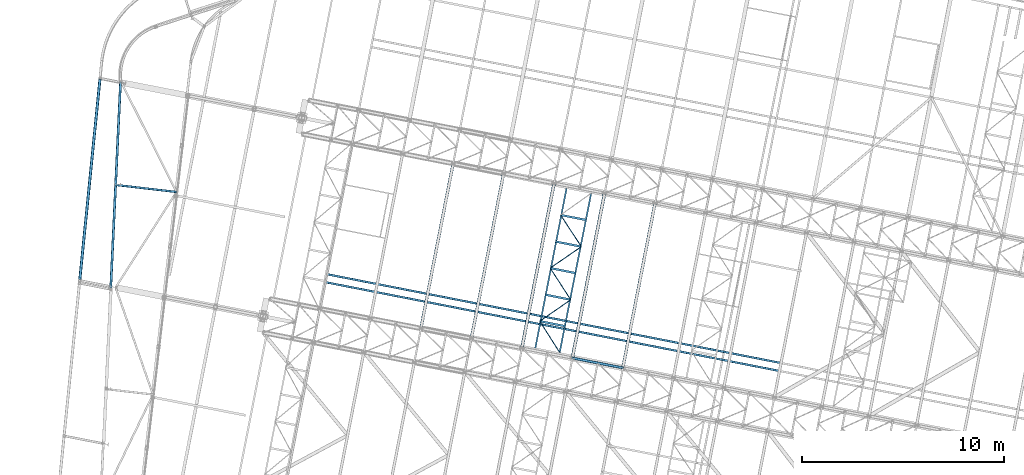
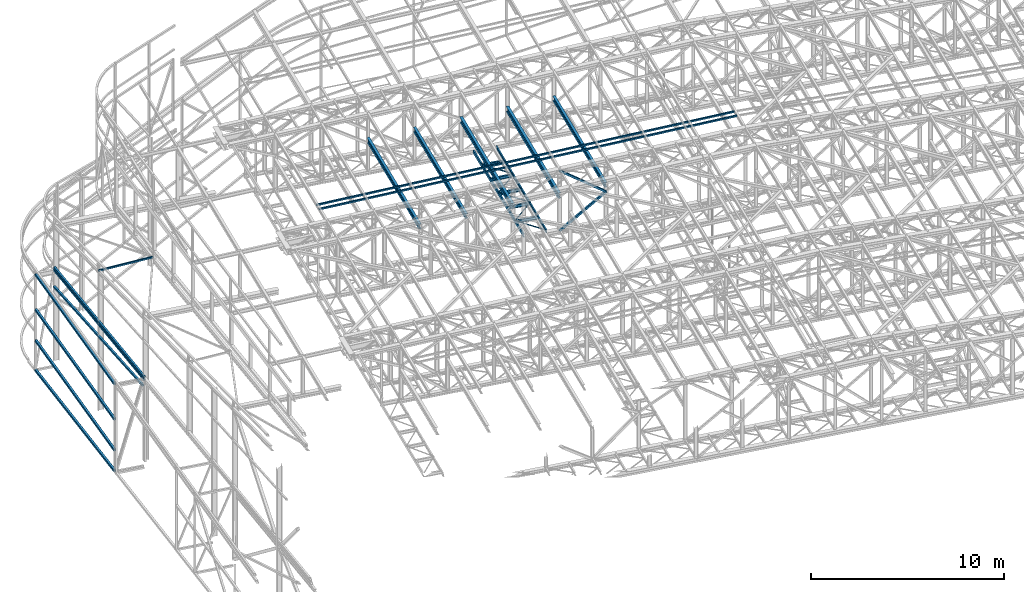
# One storey, part 75 of 215: 27 beams, 2 members, 29 elements without a shape of their own.
"""IFC2X3 building model written with IfcOpenShell, lengths in millimetres."""

from ifc_helpers import new_model, si_unit, frame, origin_with_axes, origin_2d_with_axis, place, context, subcontext, project, spatial, hollow_rectangle, i_section, u_section, extrude, material, type_object, element, aggregate, save


model = new_model("IFC2X3")

# Units and contexts
model_context = context("Model", 3, precision=1e-05, world=origin_with_axes())
body_context = subcontext(model_context, "Body", "Model", "MODEL_VIEW")
ifc_project = project(units=[si_unit("LENGTHUNIT", "METRE", prefix="MILLI"), si_unit("AREAUNIT", "SQUARE_METRE"), si_unit("VOLUMEUNIT", "CUBIC_METRE"), si_unit("MASSUNIT", "GRAM", prefix="KILO"), si_unit("TIMEUNIT", "SECOND"), si_unit("PLANEANGLEUNIT", "RADIAN"), si_unit("SOLIDANGLEUNIT", "STERADIAN"), si_unit("THERMODYNAMICTEMPERATUREUNIT", "DEGREE_CELSIUS"), si_unit("LUMINOUSINTENSITYUNIT", "LUMEN")], contexts=[model_context])

# Site, building, storey
site_placement = place(None, origin_with_axes())
site = spatial("IfcSite", under=ifc_project, at=site_placement, CompositionType="ELEMENT")
building_placement = place(site_placement, origin_with_axes())
building = spatial("IfcBuilding", under=site, at=building_placement, Name="Undefined", CompositionType="ELEMENT")
storey_placement = place(building_placement, origin_with_axes())
storey = spatial("IfcBuildingStorey", under=building, at=storey_placement, Name="Undefined", CompositionType="ELEMENT", Elevation=0.0)

# Assembly, beam
assembly_1_placement = place(storey_placement, origin_with_axes())
assembly_1 = element("IfcElementAssembly", 1, at=assembly_1_placement, inside=storey, Name="Steel Assembly", AssemblyPlace="NOTDEFINED", PredefinedType="RIGID_FRAME")
ifc_material = material(Name="STEEL/S275JR")
beam_type_1 = type_object("IfcBeamType", PredefinedType="NOTDEFINED")
beam_1_placement = place(assembly_1_placement, frame((38562.2210330828, 44215.2225875876, 5303.42054742219), z_axis=(-0.00274567599890538, -0.0584633859767245, 0.998285777602509), x_axis=(0.0475021389989792, 0.997154973978577, 0.0585278109987426)))
beam_1 = element("IfcBeam", 2, at=beam_1_placement, type_object=beam_type_1, material=ifc_material, Name="LISSE", context=body_context, shape_type="SweptSolid", body=[
    extrude(hollow_rectangle(XDim=120.0, YDim=120.0, WallThickness=5.0, InnerFilletRadius=5.0, OuterFilletRadius=10.0, at=origin_2d_with_axis()), frame((10173.8616677264, -8.40086349313258e-14, 1.41190693410765e-13), z_axis=(-1.0, 0.0, 0.0), x_axis=(-6.93889390390723e-18, -1.0, -3.46944695195361e-18)), (0.0, 0.0, 1.0), 10173.9),
])
aggregate(assembly_1, [beam_1])

assembly_2_placement = place(storey_placement, origin_with_axes())
assembly_2 = element("IfcElementAssembly", 3, at=assembly_2_placement, inside=storey, Name="Steel Assembly", AssemblyPlace="NOTDEFINED", PredefinedType="RIGID_FRAME")
beam_2_placement = place(assembly_2_placement, frame((38561.6743863728, 44200.27009948, 5139.85118866705), z_axis=(-0.00585164299790375, -0.0581866479791405, 0.998288571642076), x_axis=(0.0475199150160084, 0.997161649335921, 0.0583995100196734)))
beam_2 = element("IfcBeam", 4, at=beam_2_placement, type_object=beam_type_1, material=ifc_material, Name="LISSE", context=body_context, shape_type="SweptSolid", body=[
    extrude(hollow_rectangle(XDim=120.0, YDim=120.0, WallThickness=5.0, InnerFilletRadius=5.0, OuterFilletRadius=10.0, at=origin_2d_with_axis()), frame((10230.7652524417, -7.68136090467387e-14, 4.54747350886464e-13), z_axis=(-1.0, 0.0, 0.0), x_axis=(-6.93889390390723e-18, -1.0, -3.46944695195361e-18)), (0.0, 0.0, 1.0), 10230.8),
])
aggregate(assembly_2, [beam_2])

assembly_3_placement = place(storey_placement, origin_with_axes())
assembly_3 = element("IfcElementAssembly", 5, at=assembly_3_placement, inside=storey, Name="Steel Assembly", AssemblyPlace="NOTDEFINED", PredefinedType="RIGID_FRAME")
beam_3_placement = place(assembly_3_placement, frame((38569.3547327529, 44361.6215362705, 4673.77424776773), z_axis=(3.64340000136608e-05, -1.73599999892668e-06, 0.999999999334775), x_axis=(0.0475837119818895, 0.998867253619831, 0.0)))
beam_3 = element("IfcBeam", 6, at=beam_3_placement, type_object=beam_type_1, material=ifc_material, Name="LISSE", context=body_context, shape_type="SweptSolid", body=[
    extrude(hollow_rectangle(XDim=120.0, YDim=120.0, WallThickness=5.0, InnerFilletRadius=5.0, OuterFilletRadius=10.0, at=origin_2d_with_axis()), frame((10041.3643397933, 0.0, 0.0), z_axis=(-1.0, 0.0, 0.0), x_axis=(-6.93889390390723e-18, -1.0, -3.46944695195361e-18)), (0.0, 0.0, 1.0), 10041.4),
])
aggregate(assembly_3, [beam_3])

assembly_4_placement = place(storey_placement, origin_with_axes())
assembly_4 = element("IfcElementAssembly", 7, at=assembly_4_placement, inside=storey, Name="Steel Assembly", AssemblyPlace="NOTDEFINED", PredefinedType="RIGID_FRAME")
beam_type_2 = type_object("IfcBeamType", PredefinedType="NOTDEFINED")
beam_4_placement = place(assembly_4_placement, frame((49238.1174662719, 44889.5888265685, 12020.0732133217), z_axis=(0.0304072880144601, -0.0059443590028274, -0.99951991547525), x_axis=(0.980943093982696, -0.191809039996616, 0.0309828749994535)))
beam_4 = element("IfcBeam", 8, at=beam_4_placement, type_object=beam_type_2, material=ifc_material, context=body_context, shape_type="SweptSolid", body=[
    extrude(hollow_rectangle(XDim=100.0, YDim=100.0, WallThickness=5.0, InnerFilletRadius=5.0, OuterFilletRadius=10.0, at=origin_2d_with_axis()), frame((22902.816814498, -7.45768641912541e-12, 0.0), z_axis=(-1.0, 0.0, 0.0), x_axis=(-6.93889390390723e-18, -1.0, -3.46944695195361e-18)), (0.0, 0.0, 1.0), 22902.8),
])
aggregate(assembly_4, [beam_4])

assembly_5_placement = place(storey_placement, origin_with_axes())
assembly_5 = element("IfcElementAssembly", 9, at=assembly_5_placement, inside=storey, Name="Steel Assembly", AssemblyPlace="NOTDEFINED", PredefinedType="RIGID_FRAME")
beam_5_placement = place(assembly_5_placement, frame((49161.3570002445, 44497.0231239916, 12020.0732132829), z_axis=(0.0304072880144601, -0.0059443590028274, -0.99951991547525), x_axis=(0.980943093982696, -0.191809039996616, 0.0309828749994535)))
beam_5 = element("IfcBeam", 10, at=beam_5_placement, type_object=beam_type_2, material=ifc_material, context=body_context, shape_type="SweptSolid", body=[
    extrude(hollow_rectangle(XDim=100.0, YDim=100.0, WallThickness=5.0, InnerFilletRadius=5.0, OuterFilletRadius=10.0, at=origin_2d_with_axis()), frame((22902.816814498, -7.45768641912541e-12, 0.0), z_axis=(-1.0, 0.0, 0.0), x_axis=(-6.93889390390723e-18, -1.0, -3.46944695195361e-18)), (0.0, 0.0, 1.0), 22902.8),
])
aggregate(assembly_5, [beam_5])

assembly_6_placement = place(storey_placement, origin_with_axes())
assembly_6 = element("IfcElementAssembly", 11, at=assembly_6_placement, inside=storey, Name="Steel Assembly", AssemblyPlace="NOTDEFINED", PredefinedType="RIGID_FRAME")
beam_6_placement = place(assembly_6_placement, frame((38743.2654314975, 49309.4022806662, 8864.68109814896), z_axis=(0.115203788960212, 0.992088860657365, -0.0498776459827747), x_axis=(0.993325216792512, -0.115347360975905, -6.30000004858045e-08)))
beam_6 = element("IfcBeam", 12, at=beam_6_placement, type_object=beam_type_2, material=ifc_material, context=body_context, shape_type="SweptSolid", body=[
    extrude(hollow_rectangle(XDim=100.0, YDim=100.0, WallThickness=5.0, InnerFilletRadius=5.0, OuterFilletRadius=10.0, at=origin_2d_with_axis()), frame((3089.93072825559, -1.12759487588544e-15, -7.25438857557065e-12), z_axis=(-1.0, 0.0, 0.0), x_axis=(-6.93889390390723e-18, -1.0, -3.46944695195361e-18)), (0.0, 0.0, 1.0), 3089.9),
])
aggregate(assembly_6, [beam_6])

assembly_7_placement = place(storey_placement, origin_with_axes())
assembly_7 = element("IfcElementAssembly", 13, at=assembly_7_placement, inside=storey, Name="Steel Assembly", AssemblyPlace="NOTDEFINED", PredefinedType="RIGID_FRAME")
beam_type_3 = type_object("IfcBeamType", PredefinedType="NOTDEFINED")
beam_7_placement = place(assembly_7_placement, frame((59777.1653009629, 42564.8547260588, 8745.0), z_axis=(0.0, 0.0, -1.0), x_axis=(0.535507791031596, -0.844530287049826, 0.0)))
beam_7 = element("IfcBeam", 14, at=beam_7_placement, type_object=beam_type_3, material=ifc_material, context=body_context, shape_type="SweptSolid", body=[
    extrude(hollow_rectangle(XDim=50.0, YDim=50.0, WallThickness=3.0, InnerFilletRadius=3.0, OuterFilletRadius=6.0, at=origin_2d_with_axis()), frame((1826.33118355773, -2.02763493057671e-13, 0.0), z_axis=(-1.0, 0.0, 0.0), x_axis=(-6.93889390390723e-18, -1.0, -3.46944695195361e-18)), (0.0, 0.0, 1.0), 1826.3),
])
aggregate(assembly_7, [beam_7])

assembly_8_placement = place(storey_placement, origin_with_axes())
assembly_8 = element("IfcElementAssembly", 15, at=assembly_8_placement, inside=storey, Name="Steel Assembly", AssemblyPlace="NOTDEFINED", PredefinedType="RIGID_FRAME")
beam_8_placement = place(assembly_8_placement, frame((61307.1499519164, 43624.0938464497, 8745.0), z_axis=(0.0, 0.0, -1.0), x_axis=(-0.822187418806876, -0.569216872866298, 0.0)))
beam_8 = element("IfcBeam", 16, at=beam_8_placement, type_object=beam_type_3, material=ifc_material, context=body_context, shape_type="SweptSolid", body=[
    extrude(hollow_rectangle(XDim=50.0, YDim=50.0, WallThickness=3.0, InnerFilletRadius=3.0, OuterFilletRadius=6.0, at=origin_2d_with_axis()), frame((1860.87091076021, 0.0, 0.0), z_axis=(-1.0, 0.0, 0.0), x_axis=(-6.93889390390723e-18, -1.0, -3.46944695195361e-18)), (0.0, 0.0, 1.0), 1860.9),
])
aggregate(assembly_8, [beam_8])

assembly_9_placement = place(storey_placement, origin_with_axes())
assembly_9 = element("IfcElementAssembly", 17, at=assembly_9_placement, inside=storey, Name="Steel Assembly", AssemblyPlace="NOTDEFINED", PredefinedType="RIGID_FRAME")
beam_9_placement = place(assembly_9_placement, frame((60290.4798209445, 45190.6018396635, 8745.0), z_axis=(0.0, 0.0, -1.0), x_axis=(0.544400959129475, -0.8388251281995, 0.0)))
beam_9 = element("IfcBeam", 18, at=beam_9_placement, type_object=beam_type_3, material=ifc_material, context=body_context, shape_type="SweptSolid", body=[
    extrude(hollow_rectangle(XDim=50.0, YDim=50.0, WallThickness=3.0, InnerFilletRadius=3.0, OuterFilletRadius=6.0, at=origin_2d_with_axis()), frame((1867.50246268117, 1.46555824399975e-11, -1.81898940354586e-12), z_axis=(-1.0, 0.0, 0.0), x_axis=(-6.93889390390723e-18, -1.0, -3.46944695195361e-18)), (0.0, 0.0, 1.0), 1867.5),
])
aggregate(assembly_9, [beam_9])

assembly_10_placement = place(storey_placement, origin_with_axes())
assembly_10 = element("IfcElementAssembly", 19, at=assembly_10_placement, inside=storey, Name="Steel Assembly", AssemblyPlace="NOTDEFINED", PredefinedType="RIGID_FRAME")
beam_10_placement = place(assembly_10_placement, frame((61831.9040315537, 46250.4417372231, 8745.0), z_axis=(0.0, 0.0, -1.0), x_axis=(-0.824014283078037, -0.566569026053656, 0.0)))
beam_10 = element("IfcBeam", 20, at=beam_10_placement, type_object=beam_type_3, material=ifc_material, context=body_context, shape_type="SweptSolid", body=[
    extrude(hollow_rectangle(XDim=50.0, YDim=50.0, WallThickness=3.0, InnerFilletRadius=3.0, OuterFilletRadius=6.0, at=origin_2d_with_axis()), frame((1870.62802431259, 1.03840715155045e-13, -1.81898940354586e-12), z_axis=(-1.0, 0.0, 0.0), x_axis=(-6.93889390390723e-18, -1.0, -3.46944695195361e-18)), (0.0, 0.0, 1.0), 1870.6),
])
aggregate(assembly_10, [beam_10])

assembly_11_placement = place(storey_placement, origin_with_axes())
assembly_11 = element("IfcElementAssembly", 21, at=assembly_11_placement, inside=storey, Name="Steel Assembly", AssemblyPlace="NOTDEFINED", PredefinedType="RIGID_FRAME")
beam_11_placement = place(assembly_11_placement, frame((60803.7943409261, 47816.3489532683, 8745.0), z_axis=(0.0, 0.0, -1.0), x_axis=(0.548836682790729, -0.835929599681258, 0.0)))
beam_11 = element("IfcBeam", 22, at=beam_11_placement, type_object=beam_type_3, material=ifc_material, context=body_context, shape_type="SweptSolid", body=[
    extrude(hollow_rectangle(XDim=50.0, YDim=50.0, WallThickness=3.0, InnerFilletRadius=3.0, OuterFilletRadius=6.0, at=origin_2d_with_axis()), frame((1873.25250441599, 1.03986403066968e-13, 0.0), z_axis=(-1.0, 0.0, 0.0), x_axis=(-6.93889390390723e-18, -1.0, -3.46944695195361e-18)), (0.0, 0.0, 1.0), 1873.3),
])
aggregate(assembly_11, [beam_11])

assembly_12_placement = place(storey_placement, origin_with_axes())
assembly_12 = element("IfcElementAssembly", 23, at=assembly_12_placement, inside=storey, Name="Steel Assembly", AssemblyPlace="NOTDEFINED", PredefinedType="RIGID_FRAME")
beam_type_4 = type_object("IfcBeamType", Name="UPN200", PredefinedType="NOTDEFINED")
beam_12_placement = place(assembly_12_placement, frame((61097.2549306837, 49122.0277259823, 8670.00000003361), z_axis=(0.0, 0.0, -1.0), x_axis=(-0.191860814904866, -0.981422145513357, 0.0)))
beam_12 = element("IfcBeam", 24, at=beam_12_placement, type_object=beam_type_4, material=ifc_material, ObjectType="UPN200", context=body_context, shape_type="SweptSolid", body=[
    extrude(u_section(Depth=200.0, FlangeWidth=75.0, WebThickness=8.5, FlangeThickness=11.5, FilletRadius=11.5, EdgeRadius=6.0, FlangeSlope=0.0798299857122373, at=origin_2d_with_axis()), frame((8026.35392374698, 0.0, 0.0), z_axis=(-1.0, 0.0, 0.0), x_axis=(-6.93889390390723e-18, -1.0, -3.46944695195361e-18)), (0.0, 0.0, 1.0), 8026.4),
])
aggregate(assembly_12, [beam_12])

assembly_13_placement = place(storey_placement, origin_with_axes())
assembly_13 = element("IfcElementAssembly", 25, at=assembly_13_placement, inside=storey, Name="Steel Assembly", AssemblyPlace="NOTDEFINED", PredefinedType="RIGID_FRAME")
beam_13_placement = place(assembly_13_placement, frame((60757.1358696871, 41010.3165520345, 8669.99999999997), z_axis=(0.0, 0.0, -1.0), x_axis=(0.194048585919093, 0.980991919590982, 0.0)))
beam_13 = element("IfcBeam", 26, at=beam_13_placement, type_object=beam_type_4, material=ifc_material, ObjectType="UPN200", context=body_context, shape_type="SweptSolid", body=[
    extrude(u_section(Depth=200.0, FlangeWidth=75.0, WebThickness=8.5, FlangeThickness=11.5, FilletRadius=11.5, EdgeRadius=6.0, FlangeSlope=0.0798299857122373, at=origin_2d_with_axis()), frame((8026.37389987571, 0.0, -1.81898940354586e-12), z_axis=(-1.0, 0.0, 0.0), x_axis=(-6.93889390390723e-18, -1.0, -3.46944695195361e-18)), (0.0, 0.0, 1.0), 8026.4),
])
aggregate(assembly_13, [beam_13])

# Assembly, member
assembly_14_placement = place(storey_placement, origin_with_axes())
assembly_14 = element("IfcElementAssembly", 27, at=assembly_14_placement, inside=storey, Name="Steel Assembly", AssemblyPlace="NOTDEFINED", PredefinedType="RIGID_FRAME")
member_type = type_object("IfcMemberType", PredefinedType="NOTDEFINED")
member_1_placement = place(assembly_14_placement, frame((61386.5241832558, 40743.8532211548, 8655.0000016707), z_axis=(0.586513002916786, -0.114658631983731, -0.801782947886243), x_axis=(0.786887629166969, -0.153830279032641, 0.597615348126808)))
member_1 = element("IfcMember", 28, at=member_1_placement, type_object=member_type, material=ifc_material, context=body_context, shape_type="SweptSolid", body=[
    extrude(hollow_rectangle(XDim=120.0, YDim=120.0, WallThickness=5.0, InnerFilletRadius=5.0, OuterFilletRadius=10.0, at=origin_2d_with_axis()), frame((3174.70608727809, -7.28332097910766e-12, -3.8142103968174e-12), z_axis=(-1.0, 0.0, 0.0), x_axis=(-6.93889390390723e-18, -1.0, -3.46944695195361e-18)), (0.0, 0.0, 1.0), 3174.7),
])
aggregate(assembly_14, [member_1])

assembly_15_placement = place(storey_placement, origin_with_axes())
assembly_15 = element("IfcElementAssembly", 29, at=assembly_15_placement, inside=storey, Name="Steel Assembly", AssemblyPlace="NOTDEFINED", PredefinedType="RIGID_FRAME")
member_2_placement = place(assembly_15_placement, frame((61391.8106230572, 40743.5079109192, 12449.5061705353), z_axis=(-0.58722512481538, 0.114797160963911, -0.801241701748098), x_axis=(0.786356610610694, -0.153725552923893, -0.598340818703776)))
member_2 = element("IfcMember", 30, at=member_2_placement, type_object=member_type, material=ifc_material, context=body_context, shape_type="SweptSolid", body=[
    extrude(hollow_rectangle(XDim=120.0, YDim=120.0, WallThickness=5.0, InnerFilletRadius=5.0, OuterFilletRadius=10.0, at=origin_2d_with_axis()), frame((3170.85685098028, 7.36812737105204e-12, -1.76017914187436e-13), z_axis=(-1.0, 0.0, 0.0), x_axis=(-6.93889390390723e-18, -1.0, -3.46944695195361e-18)), (0.0, 0.0, 1.0), 3170.9),
])
aggregate(assembly_15, [member_2])

# Assembly, beam
assembly_16_placement = place(storey_placement, origin_with_axes())
assembly_16 = element("IfcElementAssembly", 31, at=assembly_16_placement, inside=storey, Name="Steel Assembly", AssemblyPlace="NOTDEFINED", PredefinedType="RIGID_FRAME")
beam_type_5 = type_object("IfcBeamType", PredefinedType="NOTDEFINED")
beam_14_placement = place(assembly_16_placement, frame((37033.3962091547, 44629.9517831955, 5135.56406380141), z_axis=(-0.00585008399815806, -0.0581728539817017, 0.998289384686043), x_axis=(0.0998879760056098, 0.993279461055785, 0.0584662680032836)))
beam_14 = element("IfcBeam", 32, at=beam_14_placement, type_object=beam_type_5, material=ifc_material, Name="LISSE", context=body_context, shape_type="SweptSolid", body=[
    extrude(hollow_rectangle(XDim=140.0, YDim=140.0, WallThickness=8.0, InnerFilletRadius=12.0, OuterFilletRadius=20.0, at=origin_2d_with_axis()), frame((9950.69528939539, 7.64058950994035e-14, 5.23794169769688e-13), z_axis=(-1.0, 0.0, 0.0), x_axis=(-6.93889390390723e-18, -1.0, -3.46944695195361e-18)), (0.0, 0.0, 1.0), 9950.7),
])
aggregate(assembly_16, [beam_14])

assembly_17_placement = place(storey_placement, origin_with_axes())
assembly_17 = element("IfcElementAssembly", 33, at=assembly_17_placement, inside=storey, Name="Steel Assembly", AssemblyPlace="NOTDEFINED", PredefinedType="RIGID_FRAME")
beam_15_placement = place(assembly_17_placement, frame((37032.9811404041, 44625.8246965398, -357.437925612628), z_axis=(-7.90469999696792e-05, -0.000781344999710626, 0.999999691625734), x_axis=(0.10006328903585, 0.994980764356481, 0.00078533300028137)))
beam_15 = element("IfcBeam", 34, at=beam_15_placement, type_object=beam_type_5, material=ifc_material, Name="LISSE", context=body_context, shape_type="SweptSolid", body=[
    extrude(hollow_rectangle(XDim=140.0, YDim=140.0, WallThickness=8.0, InnerFilletRadius=12.0, OuterFilletRadius=20.0, at=origin_2d_with_axis()), frame((9973.88934915999, 3.60882633652561e-12, -5.57620476107591e-14), z_axis=(-1.0, 0.0, 0.0), x_axis=(-6.93889390390723e-18, -1.0, -3.46944695195361e-18)), (0.0, 0.0, 1.0), 9973.9),
])
aggregate(assembly_17, [beam_15])

assembly_18_placement = place(storey_placement, origin_with_axes())
assembly_18 = element("IfcElementAssembly", 35, at=assembly_18_placement, inside=storey, Name="Steel Assembly", AssemblyPlace="NOTDEFINED", PredefinedType="RIGID_FRAME")
beam_16_placement = place(assembly_18_placement, frame((37032.9866978869, 44625.8796354954, 952.372401698805), z_axis=(-0.00586626299826645, -0.0582163579827592, 0.998286753704394), x_axis=(0.0998877130350987, 0.993276843349022, 0.05851117202056)))
beam_16 = element("IfcBeam", 36, at=beam_16_placement, type_object=beam_type_5, material=ifc_material, Name="LISSE", context=body_context, shape_type="SweptSolid", body=[
    extrude(hollow_rectangle(XDim=140.0, YDim=140.0, WallThickness=8.0, InnerFilletRadius=12.0, OuterFilletRadius=20.0, at=origin_2d_with_axis()), frame((9950.72151440229, 3.35989963901814e-12, 2.27373675443232e-13), z_axis=(-1.0, 0.0, 0.0), x_axis=(-6.93889390390723e-18, -1.0, -3.46944695195361e-18)), (0.0, 0.0, 1.0), 9950.7),
])
aggregate(assembly_18, [beam_16])

assembly_19_placement = place(storey_placement, origin_with_axes())
assembly_19 = element("IfcElementAssembly", 37, at=assembly_19_placement, inside=storey, Name="Steel Assembly", AssemblyPlace="NOTDEFINED", PredefinedType="RIGID_FRAME")
beam_17_placement = place(assembly_19_placement, frame((37032.9866978927, 44625.8796355577, 2903.95300605924), z_axis=(-0.00586209300040859, -0.0581748990040192, 0.998289195069007), x_axis=(0.0998879580439841, 0.993279272437377, 0.0584695030257462)))
beam_17 = element("IfcBeam", 38, at=beam_17_placement, type_object=beam_type_5, material=ifc_material, Name="LISSE", context=body_context, shape_type="SweptSolid", body=[
    extrude(hollow_rectangle(XDim=140.0, YDim=140.0, WallThickness=8.0, InnerFilletRadius=12.0, OuterFilletRadius=20.0, at=origin_2d_with_axis()), frame((9950.69717850362, -2.27515506409886e-13, 9.64330679049272e-13), z_axis=(-1.0, 0.0, 0.0), x_axis=(-6.93889390390723e-18, -1.0, -3.46944695195361e-18)), (0.0, 0.0, 1.0), 9950.7),
])
aggregate(assembly_19, [beam_17])

assembly_20_placement = place(storey_placement, origin_with_axes())
assembly_20 = element("IfcElementAssembly", 39, at=assembly_20_placement, inside=storey, Name="Steel Assembly", AssemblyPlace="NOTDEFINED", PredefinedType="RIGID_FRAME")
beam_type_6 = type_object("IfcBeamType", Name="IPE300", PredefinedType="NOTDEFINED")
beam_18_placement = place(assembly_20_placement, frame((63883.3237648507, 40256.4390195537, 10961.3100002071), z_axis=(0.0, 0.0, 1.0), x_axis=(0.191879342079262, 0.981418523405397, 1.00000006478113e-09)))
beam_18 = element("IfcBeam", 40, at=beam_18_placement, type_object=beam_type_6, material=ifc_material, Name="SUPPORT", ObjectType="IPE300", context=body_context, shape_type="SweptSolid", body=[
    extrude(i_section(OverallWidth=150.0, OverallDepth=300.0, WebThickness=7.099999905, FlangeThickness=10.69999981, FilletRadius=15.0, at=origin_2d_with_axis()), frame((8306.35394615426, -2.30547635042662e-13, -1.81898940354586e-12), z_axis=(-1.0, 0.0, 0.0), x_axis=(-6.93889390390723e-18, -1.0, -3.46944695195361e-18)), (0.0, 0.0, 1.0), 8306.4),
])
aggregate(assembly_20, [beam_18])

assembly_21_placement = place(storey_placement, origin_with_axes())
assembly_21 = element("IfcElementAssembly", 41, at=assembly_21_placement, inside=storey, Name="Steel Assembly", AssemblyPlace="NOTDEFINED", PredefinedType="RIGID_FRAME")
beam_19_placement = place(assembly_21_placement, frame((56394.6514479402, 41720.4086017436, 10724.7800002627), z_axis=(0.0, 0.0, 1.0), x_axis=(0.191879342079262, 0.981418523405397, 1.00000006478113e-09)))
beam_19 = element("IfcBeam", 42, at=beam_19_placement, type_object=beam_type_6, material=ifc_material, Name="SUPPORT", ObjectType="IPE300", context=body_context, shape_type="SweptSolid", body=[
    extrude(i_section(OverallWidth=150.0, OverallDepth=300.0, WebThickness=7.099999905, FlangeThickness=10.69999981, FilletRadius=15.0, at=origin_2d_with_axis()), frame((8306.35394615426, -2.30547635042662e-13, -1.81898940354586e-12), z_axis=(-1.0, 0.0, 0.0), x_axis=(-6.93889390390723e-18, -1.0, -3.46944695195361e-18)), (0.0, 0.0, 1.0), 8306.4),
])
aggregate(assembly_21, [beam_19])

assembly_22_placement = place(storey_placement, origin_with_axes())
assembly_22 = element("IfcElementAssembly", 43, at=assembly_22_placement, inside=storey, Name="Steel Assembly", AssemblyPlace="NOTDEFINED", PredefinedType="RIGID_FRAME")
beam_20_placement = place(assembly_22_placement, frame((53898.4273425851, 42208.3984624514, 10645.9400002812), z_axis=(0.0, 0.0, 1.0), x_axis=(0.191879342079262, 0.981418523405397, 1.00000006478113e-09)))
beam_20 = element("IfcBeam", 44, at=beam_20_placement, type_object=beam_type_6, material=ifc_material, Name="SUPPORT", ObjectType="IPE300", context=body_context, shape_type="SweptSolid", body=[
    extrude(i_section(OverallWidth=150.0, OverallDepth=300.0, WebThickness=7.099999905, FlangeThickness=10.69999981, FilletRadius=15.0, at=origin_2d_with_axis()), frame((8306.35394615426, -2.30547635042662e-13, -1.81898940354586e-12), z_axis=(-1.0, 0.0, 0.0), x_axis=(-6.93889390390723e-18, -1.0, -3.46944695195361e-18)), (0.0, 0.0, 1.0), 8306.4),
])
aggregate(assembly_22, [beam_20])

assembly_23_placement = place(storey_placement, origin_with_axes())
assembly_23 = element("IfcElementAssembly", 45, at=assembly_23_placement, inside=storey, Name="Steel Assembly", AssemblyPlace="NOTDEFINED", PredefinedType="RIGID_FRAME")
beam_type_7 = type_object("IfcBeamType", Name="IPE200", PredefinedType="NOTDEFINED")
beam_21_placement = place(assembly_23_placement, frame((62077.662795474, 47565.4617427177, 8670.00000000005), z_axis=(0.0, 0.0, -1.0), x_axis=(-0.981152109826579, 0.193236997965847, 0.0)))
beam_21 = element("IfcBeam", 46, at=beam_21_placement, type_object=beam_type_7, material=ifc_material, ObjectType="IPE200", context=body_context, shape_type="SweptSolid", body=[
    extrude(i_section(OverallWidth=100.0, OverallDepth=200.0, WebThickness=5.599999905, FlangeThickness=8.5, FilletRadius=12.0, at=origin_2d_with_axis()), frame((1298.33941321597, -7.20388529866689e-12, 0.0), z_axis=(-1.0, 0.0, 0.0), x_axis=(-6.93889390390723e-18, -1.0, -3.46944695195361e-18)), (0.0, 0.0, 1.0), 1298.3),
])
aggregate(assembly_23, [beam_21])

assembly_24_placement = place(storey_placement, origin_with_axes())
assembly_24 = element("IfcElementAssembly", 47, at=assembly_24_placement, inside=storey, Name="Steel Assembly", AssemblyPlace="NOTDEFINED", PredefinedType="RIGID_FRAME")
beam_22_placement = place(assembly_24_placement, frame((61821.0055354832, 46252.5881859153, 8670.00000000005), z_axis=(0.0, 0.0, -1.0), x_axis=(-0.981152109826579, 0.193236997965847, 0.0)))
beam_22 = element("IfcBeam", 48, at=beam_22_placement, type_object=beam_type_7, material=ifc_material, ObjectType="IPE200", context=body_context, shape_type="SweptSolid", body=[
    extrude(i_section(OverallWidth=100.0, OverallDepth=200.0, WebThickness=5.599999905, FlangeThickness=8.5, FilletRadius=12.0, at=origin_2d_with_axis()), frame((1298.33941321597, -7.20388529866689e-12, 0.0), z_axis=(-1.0, 0.0, 0.0), x_axis=(-6.93889390390723e-18, -1.0, -3.46944695195361e-18)), (0.0, 0.0, 1.0), 1298.3),
])
aggregate(assembly_24, [beam_22])

assembly_25_placement = place(storey_placement, origin_with_axes())
assembly_25 = element("IfcElementAssembly", 49, at=assembly_25_placement, inside=storey, Name="Steel Assembly", AssemblyPlace="NOTDEFINED", PredefinedType="RIGID_FRAME")
beam_23_placement = place(assembly_25_placement, frame((61564.3482754923, 44939.714629113, 8670.00000000005), z_axis=(0.0, 0.0, -1.0), x_axis=(-0.981152109826579, 0.193236997965847, 0.0)))
beam_23 = element("IfcBeam", 50, at=beam_23_placement, type_object=beam_type_7, material=ifc_material, ObjectType="IPE200", context=body_context, shape_type="SweptSolid", body=[
    extrude(i_section(OverallWidth=100.0, OverallDepth=200.0, WebThickness=5.599999905, FlangeThickness=8.5, FilletRadius=12.0, at=origin_2d_with_axis()), frame((1298.33941321597, -7.20388529866689e-12, 0.0), z_axis=(-1.0, 0.0, 0.0), x_axis=(-6.93889390390723e-18, -1.0, -3.46944695195361e-18)), (0.0, 0.0, 1.0), 1298.3),
])
aggregate(assembly_25, [beam_23])

assembly_26_placement = place(storey_placement, origin_with_axes())
assembly_26 = element("IfcElementAssembly", 51, at=assembly_26_placement, inside=storey, Name="Steel Assembly", AssemblyPlace="NOTDEFINED", PredefinedType="RIGID_FRAME")
beam_24_placement = place(assembly_26_placement, frame((61307.6910155016, 43626.8410723106, 8670.00000000005), z_axis=(0.0, 0.0, -1.0), x_axis=(-0.981152109826579, 0.193236997965847, 0.0)))
beam_24 = element("IfcBeam", 52, at=beam_24_placement, type_object=beam_type_7, material=ifc_material, ObjectType="IPE200", context=body_context, shape_type="SweptSolid", body=[
    extrude(i_section(OverallWidth=100.0, OverallDepth=200.0, WebThickness=5.599999905, FlangeThickness=8.5, FilletRadius=12.0, at=origin_2d_with_axis()), frame((1298.33941321597, -7.20388529866689e-12, 0.0), z_axis=(-1.0, 0.0, 0.0), x_axis=(-6.93889390390723e-18, -1.0, -3.46944695195361e-18)), (0.0, 0.0, 1.0), 1298.3),
])
aggregate(assembly_26, [beam_24])

assembly_27_placement = place(storey_placement, origin_with_axes())
assembly_27 = element("IfcElementAssembly", 53, at=assembly_27_placement, inside=storey, Name="Steel Assembly", AssemblyPlace="NOTDEFINED", PredefinedType="RIGID_FRAME")
beam_25_placement = place(assembly_27_placement, frame((61051.0337555107, 42313.9675155082, 8670.00000000005), z_axis=(0.0, 0.0, -1.0), x_axis=(-0.981152109826579, 0.193236997965847, 0.0)))
beam_25 = element("IfcBeam", 54, at=beam_25_placement, type_object=beam_type_7, material=ifc_material, ObjectType="IPE200", context=body_context, shape_type="SweptSolid", body=[
    extrude(i_section(OverallWidth=100.0, OverallDepth=200.0, WebThickness=5.599999905, FlangeThickness=8.5, FilletRadius=12.0, at=origin_2d_with_axis()), frame((1298.33941321597, -7.20388529866689e-12, 0.0), z_axis=(-1.0, 0.0, 0.0), x_axis=(-6.93889390390723e-18, -1.0, -3.46944695195361e-18)), (0.0, 0.0, 1.0), 1298.3),
])
aggregate(assembly_27, [beam_25])

assembly_28_placement = place(storey_placement, origin_with_axes())
assembly_28 = element("IfcElementAssembly", 55, at=assembly_28_placement, inside=storey, Name="Steel Assembly", AssemblyPlace="NOTDEFINED", PredefinedType="RIGID_FRAME")
beam_type_8 = type_object("IfcBeamType", Name="IPE330", PredefinedType="NOTDEFINED")
beam_26_placement = place(assembly_28_placement, frame((61387.0996588109, 40744.4288804169, 10867.4700003382), z_axis=(0.0, 0.0, 1.0), x_axis=(0.191879342079262, 0.981418523405397, 1.00000006478113e-09)))
beam_26 = element("IfcBeam", 56, at=beam_26_placement, type_object=beam_type_8, material=ifc_material, Name="SUPPORT", ObjectType="IPE330", context=body_context, shape_type="SweptSolid", body=[
    extrude(i_section(OverallWidth=160.0, OverallDepth=330.0, WebThickness=7.5, FlangeThickness=11.5, FilletRadius=18.0, at=origin_2d_with_axis()), frame((8306.35394615426, -2.30547635042662e-13, -1.81898940354586e-12), z_axis=(-1.0, 0.0, 0.0), x_axis=(-6.93889390390723e-18, -1.0, -3.46944695195361e-18)), (0.0, 0.0, 1.0), 8306.4),
])
aggregate(assembly_28, [beam_26])

assembly_29_placement = place(storey_placement, origin_with_axes())
assembly_29 = element("IfcElementAssembly", 57, at=assembly_29_placement, inside=storey, Name="Steel Assembly", AssemblyPlace="NOTDEFINED", PredefinedType="RIGID_FRAME")
beam_27_placement = place(assembly_29_placement, frame((58890.8755531979, 41232.4187410764, 10788.6300003659), z_axis=(0.0, 0.0, 1.0), x_axis=(0.191879342079262, 0.981418523405397, 1.00000006478113e-09)))
beam_27 = element("IfcBeam", 58, at=beam_27_placement, type_object=beam_type_8, material=ifc_material, Name="SUPPORT", ObjectType="IPE330", context=body_context, shape_type="SweptSolid", body=[
    extrude(i_section(OverallWidth=160.0, OverallDepth=330.0, WebThickness=7.5, FlangeThickness=11.5, FilletRadius=18.0, at=origin_2d_with_axis()), frame((8306.35394615426, -2.30547635042662e-13, -1.81898940354586e-12), z_axis=(-1.0, 0.0, 0.0), x_axis=(-6.93889390390723e-18, -1.0, -3.46944695195361e-18)), (0.0, 0.0, 1.0), 8306.4),
])
aggregate(assembly_29, [beam_27])

save(model, "model.ifc")
